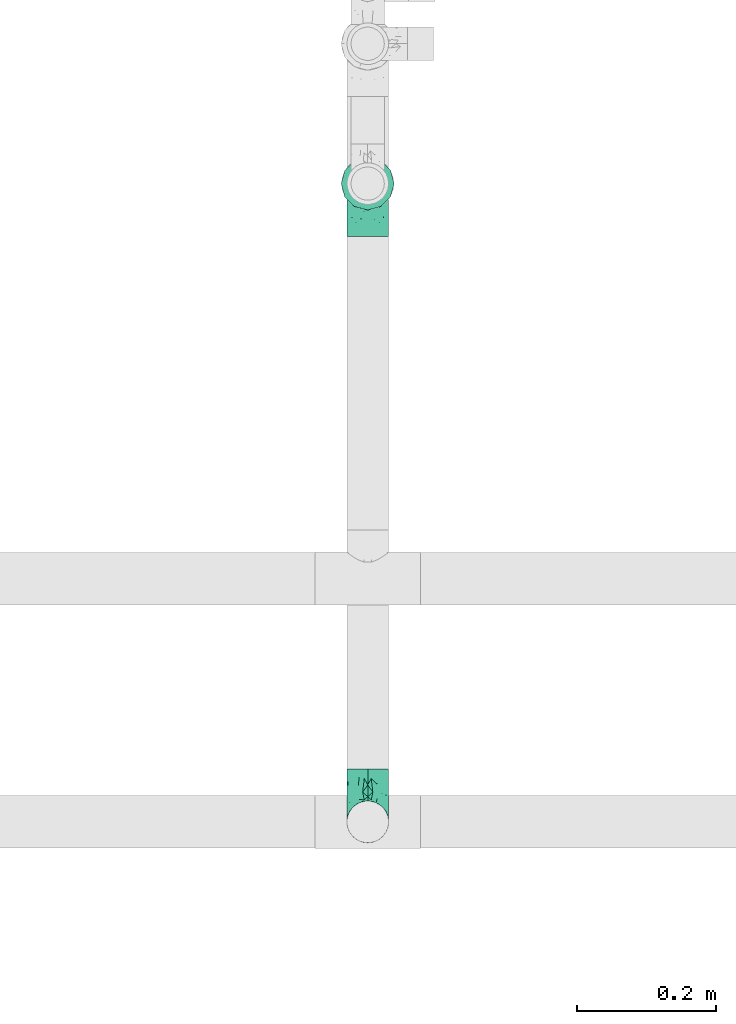
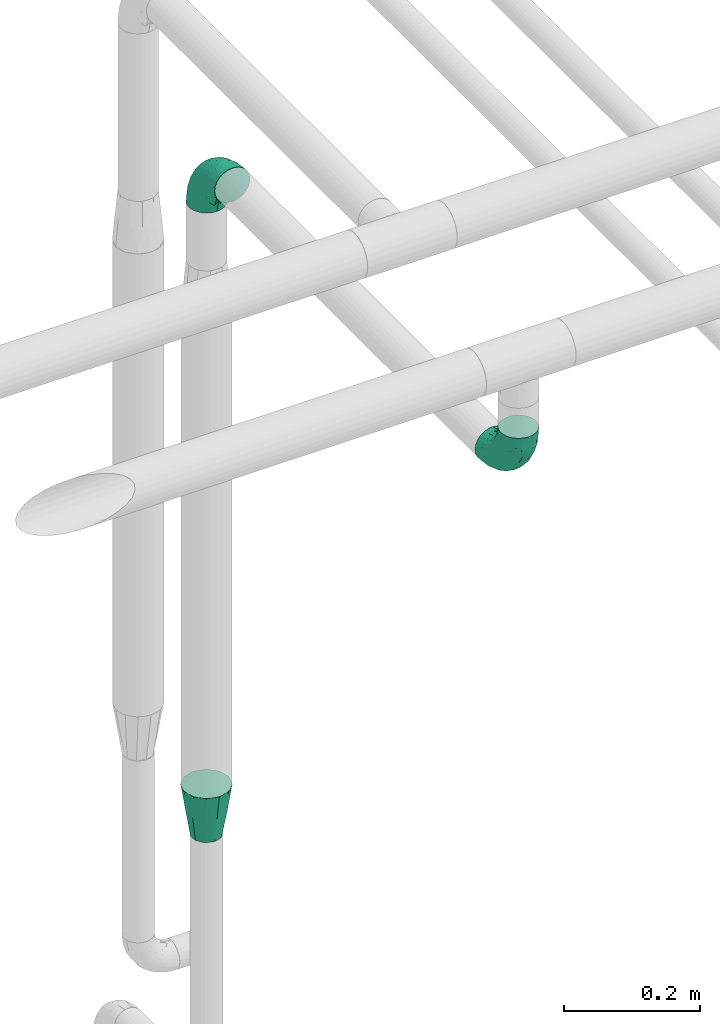
# One storey, part 786 of 827: 3 flow fittings.
"""IFC2X3 building model written with IfcOpenShell, lengths in millimetres."""

from ifc_helpers import new_model, entity, si_unit, converted_unit, derived_unit, direction, frame, origin, place, context, subcontext, project, spatial, faceted_brep, source, transform, mapped, material, type_object, type_shapes, element, save


model = new_model("IFC2X3")

# Units and contexts
model_context = context("Model", 3, precision=0.01, world=origin(), true_north=direction((6.12303176911189e-17, 1.0)))
body_context = subcontext(model_context, "Body", "Model", "MODEL_VIEW")
ifc_project = project(units=[si_unit("LENGTHUNIT", "METRE", prefix="MILLI"), si_unit("AREAUNIT", "SQUARE_METRE"), si_unit("VOLUMEUNIT", "CUBIC_METRE"), converted_unit("PLANEANGLEUNIT", "DEGREE", entity("IfcRatioMeasure", 0.0174532925199433), si_unit("PLANEANGLEUNIT", "RADIAN"), dimensions=[0, 0, 0, 0, 0, 0, 0]), si_unit("MASSUNIT", "GRAM", prefix="KILO"), derived_unit("MASSDENSITYUNIT", [(si_unit("MASSUNIT", "GRAM", prefix="KILO"), 1), (si_unit("LENGTHUNIT", "METRE"), -3)]), derived_unit("MOMENTOFINERTIAUNIT", [(si_unit("LENGTHUNIT", "METRE"), 4)]), si_unit("TIMEUNIT", "SECOND"), si_unit("FREQUENCYUNIT", "HERTZ"), si_unit("THERMODYNAMICTEMPERATUREUNIT", "DEGREE_CELSIUS"), derived_unit("THERMALTRANSMITTANCEUNIT", [(si_unit("MASSUNIT", "GRAM", prefix="KILO"), 1), (si_unit("THERMODYNAMICTEMPERATUREUNIT", "KELVIN"), -1), (si_unit("TIMEUNIT", "SECOND"), -3)]), derived_unit("VOLUMETRICFLOWRATEUNIT", [(si_unit("LENGTHUNIT", "METRE"), 3), (si_unit("TIMEUNIT", "SECOND"), -1)]), derived_unit("MASSFLOWRATEUNIT", [(si_unit("MASSUNIT", "GRAM", prefix="KILO"), 1), (si_unit("TIMEUNIT", "SECOND"), -1)]), derived_unit("ROTATIONALFREQUENCYUNIT", [(si_unit("TIMEUNIT", "SECOND"), -1)]), si_unit("ELECTRICCURRENTUNIT", "AMPERE"), si_unit("ELECTRICVOLTAGEUNIT", "VOLT"), si_unit("POWERUNIT", "WATT"), si_unit("FORCEUNIT", "NEWTON", prefix="KILO"), si_unit("ILLUMINANCEUNIT", "LUX"), si_unit("LUMINOUSFLUXUNIT", "LUMEN"), si_unit("LUMINOUSINTENSITYUNIT", "CANDELA"), derived_unit("USERDEFINED", [(si_unit("MASSUNIT", "GRAM", prefix="KILO"), -1), (si_unit("LENGTHUNIT", "METRE"), -2), (si_unit("TIMEUNIT", "SECOND"), 3), (si_unit("LUMINOUSFLUXUNIT", "LUMEN"), 1)]), derived_unit("LINEARVELOCITYUNIT", [(si_unit("LENGTHUNIT", "METRE"), 1), (si_unit("TIMEUNIT", "SECOND"), -1)]), si_unit("PRESSUREUNIT", "PASCAL"), derived_unit("USERDEFINED", [(si_unit("LENGTHUNIT", "METRE"), -2), (si_unit("MASSUNIT", "GRAM", prefix="KILO"), 1), (si_unit("TIMEUNIT", "SECOND"), -2)]), derived_unit("LINEARFORCEUNIT", [(si_unit("MASSUNIT", "GRAM", prefix="KILO"), 1), (si_unit("LENGTHUNIT", "METRE"), 1), (si_unit("TIMEUNIT", "SECOND"), -2), (si_unit("LENGTHUNIT", "METRE"), -1)]), derived_unit("PLANARFORCEUNIT", [(si_unit("MASSUNIT", "GRAM", prefix="KILO"), 1), (si_unit("LENGTHUNIT", "METRE"), 1), (si_unit("TIMEUNIT", "SECOND"), -2), (si_unit("LENGTHUNIT", "METRE"), -2)])], contexts=[model_context])

# Site, building, storey
site_placement = place(None, origin())
site = spatial("IfcSite", under=ifc_project, at=site_placement, CompositionType="ELEMENT")
building_placement = place(site_placement, origin())
building = spatial("IfcBuilding", under=site, at=building_placement, CompositionType="ELEMENT")
storey_placement = place(building_placement, frame((0.0, 0.0, 28200.0)))
storey = spatial("IfcBuildingStorey", under=building, at=storey_placement, Name="08", CompositionType="ELEMENT", Elevation=28200.0)

# Flow fittings
ifc_material = material()
pipe_fitting_type_1 = type_object("IfcPipeFittingType", Name="ADSK_1", PredefinedType="NOTDEFINED", material=ifc_material)
shared_shape_1 = source(origin(), body_context, "Body", "Brep", [
    faceted_brep([(-76.0, 15.07, -26.11), (-76.0, 7.8, -29.12), (-76.0, 0.0, -30.15), (-76.0, -7.8, -29.12), (-76.0, -15.08, -26.11), (-76.0, -21.32, -21.32), (-76.0, -26.11, -15.08), (-76.0, -29.12, -7.8), (-76.0, -30.15, 0.0), (-76.0, -29.12, 7.8), (-76.0, -26.11, 15.07), (-76.0, -21.32, 21.32), (-76.0, -15.08, 26.11), (-76.0, -7.8, 29.12), (-76.0, 0.0, 30.15), (-76.0, 7.8, 29.12), (-76.0, 15.07, 26.11), (-76.0, 21.32, 21.32), (-76.0, 26.11, 15.07), (-76.0, 29.12, 7.8), (-76.0, 30.15, 0.0), (-76.0, 29.12, -7.8), (-76.0, 26.11, -15.08), (-76.0, 21.32, -21.32), (0.0, 76.0, -30.15), (-7.8, 76.0, -29.12), (-15.07, 76.0, -26.11), (-21.32, 76.0, -21.32), (-26.11, 76.0, -15.08), (-29.12, 76.0, -7.8), (-30.15, 76.0, 0.0), (-29.12, 76.0, 7.8), (-26.11, 76.0, 15.07), (-21.32, 76.0, 21.32), (-15.07, 76.0, 26.11), (-7.8, 76.0, 29.12), (0.0, 76.0, 30.15), (7.8, 76.0, 29.12), (15.08, 76.0, 26.11), (21.32, 76.0, 21.32), (26.11, 76.0, 15.07), (29.12, 76.0, 7.8), (30.15, 76.0, 0.0), (29.12, 76.0, -7.8), (26.11, 76.0, -15.08), (21.32, 76.0, -21.32), (15.08, 76.0, -26.11), (7.8, 76.0, -29.12), (10.79, 31.43, 21.07), (4.32, 31.7, 25.72), (1.65, 15.19, 19.92), (-61.17, -27.8, 0.0), (-51.1, -25.49, 9.84), (-56.14, -10.61, 27.27), (-31.7, -4.32, 25.72), (-39.75, 1.72, 29.41), (-43.2, -24.95, 0.0), (-1.86, 1.86, 0.0), (4.49, 7.65, 5.78), (-7.82, -4.61, 5.83), (-56.21, -22.79, 17.21), (-58.98, -3.38, 29.7), (-53.96, 5.6, 30.07), (-10.86, 10.86, 25.48), (-17.2, -2.6, 20.44), (-49.15, -16.01, 22.7), (-22.18, -14.24, 7.99), (-28.4, -17.42, 0.0), (-13.61, -9.88, 0.0), (-39.0, 23.48, 27.76), (-58.76, 12.54, 28.36), (-41.61, 15.41, 29.48), (16.01, 49.15, 22.7), (-58.55, 25.93, 19.53), (-51.53, 33.5, 13.51), (-64.92, 28.76, 12.4), (-7.48, 23.14, 28.25), (-1.72, 39.75, 29.41), (-12.04, 27.88, 29.88), (-63.91, 18.81, 24.52), (-11.63, 65.16, 28.18), (-4.97, 57.02, 30.05), (9.88, 13.61, 0.0), (-62.5, 31.74, 5.02), (-45.17, 30.98, 21.2), (-21.78, 9.76, 28.58), (10.61, 56.14, 27.27), (-32.09, 54.42, 13.26), (22.79, 56.21, 17.21), (15.38, 31.17, 15.63), (25.49, 51.1, 9.84), (21.84, 36.35, 5.92), (24.95, 43.2, 0.0), (3.38, 58.98, 29.7), (-31.17, -15.38, 15.63), (-39.39, 41.78, 15.45), (-34.56, 41.13, 20.79), (-39.81, -23.25, 5.49), (27.8, 61.17, 0.0), (-31.74, 62.5, 5.02), (-53.07, 36.29, 0.0), (-42.95, 42.95, 7.29), (-36.29, 53.07, 0.0), (-19.83, 58.51, 24.79), (-25.48, 60.2, 19.41), (-14.53, 50.96, 28.57), (-13.31, 37.09, 30.07), (-26.16, 40.06, 26.4), (-32.43, -10.35, 21.9), (17.42, 28.4, 0.0), (14.24, 22.18, 7.99), (-38.67, 9.72, 30.15), (-24.66, 17.36, 30.09), (-37.08, 31.49, 24.99), (-49.27, 22.83, 25.24), (-20.8, 38.81, 28.63), (-27.58, 27.58, 29.2), (-36.07, -20.23, 10.71), (-15.19, -6.16, 14.9), (6.6, 15.4, 14.49), (-2.51, 2.51, 11.35), (-65.16, 11.63, -28.18), (-49.15, -16.01, -22.7), (-57.02, 4.97, -30.05), (-25.93, 58.55, -19.53), (-33.5, 51.53, -13.51), (-28.76, 64.92, -12.4), (-60.2, 25.48, -19.41), (-58.51, 19.83, -24.79), (-7.65, -4.49, -5.78), (-62.5, 31.74, -5.02), (-50.96, 14.53, -28.57), (-37.09, 13.31, -30.07), (-42.95, 42.95, -7.29), (25.49, 51.1, -9.84), (22.79, 56.21, -17.21), (-40.06, 26.16, -26.4), (3.38, 58.98, -29.7), (-5.6, 53.96, -30.07), (-27.88, 12.04, -29.88), (-9.76, 21.78, -28.58), (-23.14, 7.48, -28.25), (-51.1, -25.49, -9.84), (15.38, 31.17, -15.63), (16.01, 49.15, -22.7), (-23.48, 39.0, -27.76), (-12.54, 58.76, -28.36), (-15.41, 41.61, -29.48), (-56.21, -22.79, -17.21), (-9.72, 38.67, -30.15), (-17.36, 24.66, -30.09), (-22.18, -14.24, -7.99), (-41.13, 34.56, -20.79), (-31.74, 62.5, -5.02), (-58.98, -3.38, -29.7), (-31.17, -15.38, -15.63), (-56.14, -10.61, -27.27), (14.24, 22.18, -7.99), (23.25, 39.81, -5.49), (-31.49, 37.08, -24.99), (4.61, 7.82, -5.83), (-15.19, -6.16, -14.9), (1.65, 15.19, -19.92), (-2.51, 2.51, -11.35), (-18.81, 63.91, -24.52), (-32.59, -11.62, -20.84), (-31.7, -4.32, -25.72), (-17.2, -2.6, -20.44), (-39.75, 1.72, -29.41), (-54.42, 32.09, -13.26), (-30.98, 45.17, -21.2), (10.61, 56.14, -27.27), (10.23, 31.31, -21.52), (4.32, 31.7, -25.72), (-41.78, 39.39, -15.45), (-1.72, 39.75, -29.41), (-36.35, -21.84, -5.92), (-22.83, 49.27, -25.24), (-38.81, 20.8, -28.63), (-27.58, 27.58, -29.2), (-10.86, 10.86, -25.48), (20.23, 36.07, -10.71), (6.6, 15.4, -14.49)], [[[0, 1, 2, 3, 4, 5, 6, 7, 8, 9, 10, 11, 12, 13, 14, 15, 16, 17, 18, 19, 20, 21, 22, 23]], [[24, 25, 26, 27, 28, 29, 30, 31, 32, 33, 34, 35, 36, 37, 38, 39, 40, 41, 42, 43, 44, 45, 46, 47]], [[48, 49, 50]], [[51, 52, 9]], [[53, 54, 55]], [[9, 52, 10]], [[56, 52, 51]], [[57, 58, 59]], [[11, 10, 60]], [[14, 61, 62]], [[63, 54, 64]], [[65, 12, 11]], [[65, 53, 12]], [[66, 67, 68]], [[69, 70, 71]], [[72, 39, 38]], [[73, 74, 75]], [[15, 70, 16]], [[76, 77, 78]], [[16, 79, 17]], [[13, 61, 14]], [[35, 80, 81]], [[14, 62, 15]], [[17, 73, 18]], [[58, 57, 82]], [[20, 19, 83]], [[75, 19, 18]], [[70, 15, 62]], [[73, 84, 74]], [[78, 85, 76]], [[38, 86, 72]], [[32, 31, 87]], [[88, 89, 90]], [[91, 92, 90]], [[72, 86, 49]], [[36, 93, 37]], [[75, 83, 19]], [[36, 35, 81]], [[60, 94, 65]], [[40, 90, 41]], [[95, 96, 87]], [[88, 90, 40]], [[66, 97, 67]], [[90, 98, 41]], [[40, 39, 88]], [[99, 31, 30]], [[20, 83, 100]], [[101, 102, 100]], [[52, 60, 10]], [[102, 99, 30]], [[96, 103, 104]], [[83, 101, 100]], [[12, 53, 13]], [[104, 103, 33]], [[105, 106, 81]], [[107, 105, 103]], [[64, 54, 108]], [[80, 103, 105]], [[80, 35, 34]], [[34, 33, 103]], [[86, 38, 37]], [[109, 110, 82]], [[71, 111, 112]], [[69, 107, 113]], [[79, 73, 17]], [[114, 113, 84]], [[33, 32, 104]], [[115, 107, 116]], [[105, 115, 106]], [[93, 81, 77]], [[54, 53, 65]], [[61, 53, 55]], [[108, 94, 64]], [[54, 63, 85]], [[93, 86, 37]], [[77, 76, 49]], [[77, 49, 86]], [[49, 63, 50]], [[60, 52, 117]], [[65, 11, 60]], [[39, 72, 88]], [[89, 88, 72]], [[71, 70, 62]], [[79, 70, 114]], [[103, 96, 107]], [[69, 113, 114]], [[112, 106, 116]], [[77, 81, 106]], [[112, 116, 71]], [[112, 55, 85]], [[64, 50, 63]], [[57, 59, 68]], [[32, 87, 104]], [[96, 104, 87]], [[94, 118, 64]], [[50, 119, 89]], [[50, 64, 118]], [[50, 89, 48]], [[81, 93, 36]], [[86, 93, 77]], [[53, 61, 13]], [[62, 61, 55]], [[71, 62, 111]], [[69, 71, 116]], [[95, 101, 74]], [[99, 101, 87]], [[118, 66, 59]], [[117, 97, 66]], [[117, 66, 94]], [[91, 89, 110]], [[91, 110, 109]], [[110, 89, 119]], [[9, 8, 51]], [[98, 90, 92]], [[98, 42, 41]], [[101, 83, 74]], [[101, 99, 102]], [[87, 31, 99]], [[62, 55, 111]], [[55, 112, 111]], [[107, 69, 116]], [[70, 69, 114]], [[107, 96, 113]], [[84, 113, 96]], [[84, 96, 95]], [[114, 84, 73]], [[70, 79, 16]], [[73, 79, 114]], [[54, 85, 55]], [[76, 85, 63]], [[49, 76, 63]], [[77, 106, 78]], [[106, 112, 78]], [[85, 78, 112]], [[73, 75, 18]], [[83, 75, 74]], [[103, 80, 34]], [[81, 80, 105]], [[101, 95, 87]], [[84, 95, 74]], [[106, 115, 116]], [[105, 107, 115]], [[110, 119, 58]], [[110, 58, 82]], [[58, 120, 59]], [[118, 59, 120]], [[66, 68, 59]], [[54, 65, 108]], [[94, 108, 65]], [[66, 118, 94]], [[50, 118, 120]], [[50, 120, 119]], [[119, 120, 58]], [[89, 72, 48]], [[49, 48, 72]], [[60, 117, 94]], [[117, 52, 97]], [[52, 56, 97]], [[67, 97, 56]], [[92, 91, 109]], [[89, 91, 90]], [[121, 1, 0]], [[122, 5, 4]], [[2, 1, 123]], [[124, 125, 126]], [[127, 128, 23]], [[68, 129, 57]], [[100, 130, 20]], [[131, 132, 123]], [[133, 100, 102]], [[134, 135, 44]], [[131, 128, 136]], [[24, 137, 138]], [[139, 140, 141]], [[121, 128, 131]], [[6, 142, 7]], [[135, 143, 144]], [[142, 51, 7]], [[145, 146, 147]], [[142, 6, 148]], [[147, 149, 150]], [[151, 68, 67]], [[152, 128, 127]], [[30, 153, 102]], [[43, 42, 98]], [[154, 3, 2]], [[155, 142, 148]], [[156, 4, 3]], [[24, 138, 25]], [[153, 133, 102]], [[157, 158, 109]], [[30, 29, 153]], [[145, 136, 159]], [[27, 124, 28]], [[57, 160, 82]], [[161, 162, 163]], [[27, 26, 164]], [[146, 26, 25]], [[165, 166, 167]], [[24, 47, 137]], [[141, 168, 139]], [[22, 21, 169]], [[125, 124, 170]], [[146, 25, 138]], [[46, 144, 171]], [[156, 122, 4]], [[0, 23, 128]], [[1, 121, 123]], [[109, 82, 157]], [[45, 44, 135]], [[144, 46, 45]], [[134, 43, 98]], [[130, 21, 20]], [[134, 98, 92]], [[172, 173, 144]], [[46, 171, 47]], [[43, 134, 44]], [[174, 152, 169]], [[171, 173, 175]], [[6, 5, 148]], [[126, 29, 28]], [[176, 56, 142]], [[122, 156, 166]], [[164, 124, 27]], [[177, 159, 170]], [[23, 22, 127]], [[178, 136, 179]], [[131, 178, 132]], [[154, 123, 168]], [[154, 156, 3]], [[168, 141, 166]], [[168, 166, 156]], [[166, 180, 167]], [[173, 171, 144]], [[137, 171, 175]], [[172, 143, 162]], [[173, 180, 140]], [[5, 122, 148]], [[155, 148, 122]], [[135, 134, 181]], [[144, 45, 135]], [[147, 146, 138]], [[164, 146, 177]], [[128, 152, 136]], [[145, 159, 177]], [[150, 132, 179]], [[168, 123, 132]], [[150, 179, 147]], [[150, 175, 140]], [[57, 129, 160]], [[155, 165, 167]], [[22, 169, 127]], [[152, 127, 169]], [[162, 167, 180]], [[161, 155, 167]], [[173, 162, 180]], [[182, 162, 143]], [[123, 154, 2]], [[156, 154, 168]], [[171, 137, 47]], [[138, 137, 175]], [[147, 138, 149]], [[145, 147, 179]], [[174, 133, 125]], [[130, 133, 169]], [[176, 155, 151]], [[176, 151, 67]], [[151, 155, 161]], [[182, 157, 160]], [[181, 158, 157]], [[181, 157, 143]], [[51, 142, 56]], [[51, 8, 7]], [[133, 130, 100]], [[169, 21, 130]], [[126, 153, 29]], [[133, 153, 125]], [[138, 175, 149]], [[175, 150, 149]], [[136, 145, 179]], [[146, 145, 177]], [[136, 152, 159]], [[170, 159, 152]], [[170, 152, 174]], [[177, 170, 124]], [[146, 164, 26]], [[124, 164, 177]], [[173, 140, 175]], [[141, 140, 180]], [[166, 141, 180]], [[168, 132, 139]], [[132, 150, 139]], [[140, 139, 150]], [[124, 126, 28]], [[153, 126, 125]], [[128, 121, 0]], [[123, 121, 131]], [[133, 174, 169]], [[170, 174, 125]], [[132, 178, 179]], [[131, 136, 178]], [[151, 161, 129]], [[151, 129, 68]], [[129, 163, 160]], [[182, 160, 163]], [[157, 82, 160]], [[155, 122, 165]], [[166, 165, 122]], [[162, 161, 167]], [[161, 163, 129]], [[143, 172, 144]], [[162, 173, 172]], [[157, 182, 143]], [[163, 162, 182]], [[56, 176, 67]], [[155, 176, 142]], [[135, 181, 143]], [[181, 134, 158]], [[134, 92, 158]], [[109, 158, 92]]]),
])
type_shapes(pipe_fitting_type_1, [shared_shape_1])
flow_fitting_1_placement = place(storey_placement, frame((15025.95, 15318.04, 2600.0), z_axis=(-1.0, 0.0, 0.0), x_axis=(0.0, 1.0, -5.95708716508338e-07)))
element("IfcFlowFitting", 1, at=flow_fitting_1_placement, inside=storey, type_object=pipe_fitting_type_1, material=ifc_material, Name="ADSK_1", ObjectType="ADSK_1", context=body_context, shape_type="MappedRepresentation", body=[
    mapped(shared_shape_1, transform((0.0, 0.0, 0.0), scale=1.0)),
])
pipe_fitting_type_2 = type_object("IfcPipeFittingType", Name="ADSK_1", PredefinedType="NOTDEFINED", material=ifc_material)
shared_shape_2 = source(origin(), body_context, "Body", "Brep", [
    faceted_brep([(89.0, 19.02, -32.97), (89.0, 25.99, -26.0), (89.0, 32.95, -19.04), (89.0, 35.5, -9.53), (89.0, 38.05, -0.02), (89.0, 35.5, 9.5), (89.0, 32.95, 19.01), (89.0, 25.99, 25.97), (89.0, 19.02, 32.94), (89.0, 9.51, 35.49), (89.0, 0.0, 38.03), (89.0, -9.51, 35.49), (89.0, -19.03, 32.94), (89.0, -25.99, 25.97), (89.0, -32.95, 19.01), (89.0, -35.5, 9.5), (89.0, -38.05, -0.02), (89.0, -35.5, -9.53), (89.0, -32.95, -19.04), (89.0, -25.99, -26.0), (89.0, -19.03, -32.97), (89.0, -9.51, -35.52), (89.0, 0.0, -38.07), (89.0, 9.51, -35.52), (0.0, 19.54, 14.2), (0.0, 21.84, 7.1), (0.0, 24.15, 0.0), (0.0, 21.84, -7.1), (0.0, 19.54, -14.2), (0.0, 13.5, -18.58), (0.0, 7.46, -22.97), (0.0, 0.0, -22.97), (0.0, -7.46, -22.97), (0.0, -13.5, -18.58), (0.0, -19.54, -14.2), (0.0, -21.84, -7.1), (0.0, -24.15, 0.0), (0.0, -21.84, 7.1), (0.0, -19.54, 14.2), (0.0, -13.5, 18.58), (0.0, -7.46, 22.97), (0.0, 0.0, 22.97), (0.0, 7.46, 22.97), (0.0, 13.5, 18.58), (42.75, -30.0, -7.08), (42.46, -27.91, -12.99), (48.81, -9.76, -30.25), (39.14, -14.23, -26.72), (49.37, -25.28, -19.4), (44.38, -20.22, -23.61), (44.38, 23.61, -20.22), (39.14, 26.71, -14.23), (44.5, -4.06, -30.84), (45.84, 10.19, -29.61), (49.37, 19.4, -25.28), (44.72, 29.79, -9.06), (44.5, 4.06, -30.84), (44.5, -31.1, -0.01), (42.65, -30.81, -0.01), (42.66, 30.81, -0.01), (44.5, 31.1, -0.01), (42.75, 30.0, 7.07), (42.46, 27.91, 12.97), (48.81, 9.76, 30.23), (39.14, 14.23, 26.7), (49.37, 25.28, 19.39), (44.38, 20.22, 23.6), (44.38, -23.61, 20.21), (39.14, -26.71, 14.22), (44.5, 4.06, 30.83), (45.84, -10.19, 29.6), (49.37, -19.4, 25.27), (44.72, -29.79, 9.05), (44.5, -4.06, 30.83)], [[[0, 1, 2, 3, 4, 5, 6, 7, 8, 9, 10, 11, 12, 13, 14, 15, 16, 17, 18, 19, 20, 21, 22, 23]], [[24, 25, 26, 27, 28, 29, 30, 31, 32, 33, 34, 35, 36, 37, 38, 39, 40, 41, 42, 43]], [[44, 45, 17]], [[20, 46, 21]], [[33, 32, 47]], [[19, 48, 49]], [[34, 49, 48]], [[50, 51, 2]], [[45, 48, 18]], [[49, 20, 19]], [[21, 52, 22]], [[48, 45, 34]], [[53, 29, 54]], [[35, 45, 44]], [[45, 18, 17]], [[55, 51, 27]], [[18, 48, 19]], [[22, 56, 23]], [[44, 16, 57, 58, 36]], [[53, 54, 0]], [[59, 55, 26]], [[49, 34, 33]], [[34, 45, 35]], [[31, 30, 56, 52, 32]], [[49, 33, 47]], [[47, 20, 49]], [[32, 52, 46]], [[20, 47, 46]], [[53, 23, 56]], [[56, 22, 52]], [[36, 35, 44]], [[52, 21, 46]], [[53, 56, 30]], [[1, 54, 50]], [[0, 23, 53]], [[53, 30, 29]], [[2, 1, 50]], [[0, 54, 1]], [[50, 29, 28]], [[29, 50, 54]], [[50, 28, 51]], [[28, 27, 51]], [[59, 3, 55]], [[55, 27, 26]], [[2, 51, 55]], [[3, 59, 60, 4]], [[2, 55, 3]], [[16, 44, 17]], [[32, 46, 47]], [[61, 62, 5]], [[8, 63, 9]], [[43, 42, 64]], [[7, 65, 66]], [[24, 66, 65]], [[67, 68, 14]], [[62, 65, 6]], [[66, 8, 7]], [[9, 69, 10]], [[65, 62, 24]], [[70, 39, 71]], [[25, 62, 61]], [[62, 6, 5]], [[72, 68, 37]], [[6, 65, 7]], [[10, 73, 11]], [[61, 4, 60, 59, 26]], [[70, 71, 12]], [[58, 72, 36]], [[66, 24, 43]], [[24, 62, 25]], [[41, 40, 73, 69, 42]], [[66, 43, 64]], [[64, 8, 66]], [[42, 69, 63]], [[8, 64, 63]], [[70, 11, 73]], [[73, 10, 69]], [[26, 25, 61]], [[69, 9, 63]], [[70, 73, 40]], [[13, 71, 67]], [[12, 11, 70]], [[70, 40, 39]], [[14, 13, 67]], [[12, 71, 13]], [[67, 39, 38]], [[39, 67, 71]], [[67, 38, 68]], [[38, 37, 68]], [[58, 15, 72]], [[72, 37, 36]], [[14, 68, 72]], [[15, 58, 57, 16]], [[14, 72, 15]], [[4, 61, 5]], [[42, 63, 64]]]),
])
type_shapes(pipe_fitting_type_2, [shared_shape_2])
flow_fitting_2_placement = place(storey_placement, frame((15025.81, 15318.04, 1388.64), z_axis=(1.0, 0.0, 0.0), x_axis=(0.0, 0.0, 1.0)))
element("IfcFlowFitting", 2, at=flow_fitting_2_placement, inside=storey, type_object=pipe_fitting_type_2, material=ifc_material, Name="ADSK_1", ObjectType="ADSK_1", context=body_context, shape_type="MappedRepresentation", body=[
    mapped(shared_shape_2, transform((0.0, 0.0, 0.0), scale=1.0)),
])
pipe_fitting_type_3 = type_object("IfcPipeFittingType", Name="ADSK_1", PredefinedType="NOTDEFINED", material=ifc_material)
shared_shape_3 = source(origin(), body_context, "Body", "Brep", [
    faceted_brep([(-76.0, 15.07, -26.11), (-76.0, 7.8, -29.12), (-76.0, 0.0, -30.15), (-76.0, -7.8, -29.12), (-76.0, -15.08, -26.11), (-76.0, -21.32, -21.32), (-76.0, -26.11, -15.08), (-76.0, -29.12, -7.8), (-76.0, -30.15, 0.0), (-76.0, -29.12, 7.8), (-76.0, -26.11, 15.07), (-76.0, -21.32, 21.32), (-76.0, -15.08, 26.11), (-76.0, -7.8, 29.12), (-76.0, 0.0, 30.15), (-76.0, 7.8, 29.12), (-76.0, 15.07, 26.11), (-76.0, 21.32, 21.32), (-76.0, 26.11, 15.07), (-76.0, 29.12, 7.8), (-76.0, 30.15, 0.0), (-76.0, 29.12, -7.8), (-76.0, 26.11, -15.08), (-76.0, 21.32, -21.32), (0.0, 76.0, -30.15), (-7.8, 76.0, -29.12), (-15.08, 76.0, -26.11), (-21.32, 76.0, -21.32), (-26.11, 76.0, -15.08), (-29.12, 76.0, -7.8), (-30.15, 76.0, 0.0), (-29.12, 76.0, 7.8), (-26.11, 76.0, 15.07), (-21.32, 76.0, 21.32), (-15.08, 76.0, 26.11), (-7.8, 76.0, 29.12), (0.0, 76.0, 30.15), (7.8, 76.0, 29.12), (15.07, 76.0, 26.11), (21.32, 76.0, 21.32), (26.11, 76.0, 15.07), (29.12, 76.0, 7.8), (30.15, 76.0, 0.0), (29.12, 76.0, -7.8), (26.11, 76.0, -15.08), (21.32, 76.0, -21.32), (15.07, 76.0, -26.11), (7.8, 76.0, -29.12), (10.79, 31.43, 21.07), (4.32, 31.7, 25.72), (1.65, 15.19, 19.92), (-61.17, -27.8, 0.0), (-51.1, -25.49, 9.84), (-56.14, -10.61, 27.27), (-31.7, -4.32, 25.72), (-39.75, 1.72, 29.41), (-43.2, -24.95, 0.0), (-1.86, 1.86, 0.0), (4.49, 7.65, 5.78), (-7.82, -4.61, 5.83), (-56.21, -22.79, 17.21), (-58.98, -3.38, 29.7), (-53.96, 5.6, 30.07), (-10.86, 10.86, 25.48), (-17.2, -2.6, 20.44), (-49.15, -16.01, 22.7), (-22.18, -14.24, 7.99), (-28.4, -17.42, 0.0), (-13.61, -9.88, 0.0), (-39.0, 23.48, 27.76), (-58.76, 12.54, 28.36), (-41.61, 15.41, 29.48), (16.01, 49.15, 22.7), (-58.55, 25.93, 19.53), (-51.53, 33.5, 13.51), (-64.92, 28.76, 12.4), (-7.48, 23.14, 28.25), (-1.72, 39.75, 29.41), (-12.04, 27.88, 29.88), (-63.91, 18.81, 24.52), (-11.63, 65.16, 28.18), (-4.97, 57.02, 30.05), (9.88, 13.61, 0.0), (-62.5, 31.74, 5.02), (-45.17, 30.98, 21.2), (-21.78, 9.76, 28.58), (10.61, 56.14, 27.27), (-32.09, 54.42, 13.26), (22.79, 56.21, 17.21), (15.38, 31.17, 15.63), (25.49, 51.1, 9.84), (21.84, 36.35, 5.92), (24.95, 43.2, 0.0), (3.38, 58.98, 29.7), (-31.17, -15.38, 15.63), (-39.39, 41.78, 15.45), (-34.56, 41.13, 20.79), (-39.81, -23.25, 5.49), (27.8, 61.17, 0.0), (-31.74, 62.5, 5.02), (-53.08, 36.29, 0.0), (-42.95, 42.95, 7.29), (-36.29, 53.08, 0.0), (-19.83, 58.51, 24.79), (-25.48, 60.2, 19.41), (-14.53, 50.96, 28.57), (-13.31, 37.09, 30.07), (-26.16, 40.06, 26.4), (-32.43, -10.35, 21.9), (17.42, 28.4, 0.0), (14.24, 22.18, 7.99), (-38.67, 9.72, 30.15), (-24.66, 17.36, 30.09), (-37.08, 31.49, 24.99), (-49.27, 22.83, 25.24), (-20.8, 38.81, 28.63), (-27.58, 27.58, 29.2), (-36.07, -20.23, 10.71), (-15.19, -6.16, 14.9), (6.6, 15.4, 14.49), (-2.51, 2.51, 11.35), (-65.16, 11.63, -28.18), (-49.15, -16.01, -22.7), (-57.02, 4.97, -30.05), (-25.93, 58.55, -19.53), (-33.5, 51.53, -13.51), (-28.76, 64.92, -12.4), (-60.2, 25.48, -19.41), (-58.51, 19.83, -24.79), (-7.65, -4.49, -5.78), (-62.5, 31.74, -5.02), (-50.96, 14.53, -28.57), (-37.09, 13.31, -30.07), (-42.95, 42.95, -7.29), (25.49, 51.1, -9.84), (22.79, 56.21, -17.21), (-40.06, 26.16, -26.4), (3.38, 58.98, -29.7), (-5.6, 53.96, -30.07), (-27.88, 12.04, -29.88), (-9.76, 21.78, -28.58), (-23.14, 7.48, -28.25), (-51.1, -25.49, -9.84), (15.38, 31.17, -15.63), (16.01, 49.15, -22.7), (-23.48, 39.0, -27.76), (-12.54, 58.76, -28.36), (-15.41, 41.61, -29.48), (-56.21, -22.79, -17.21), (-9.72, 38.67, -30.15), (-17.36, 24.66, -30.09), (-22.18, -14.24, -7.99), (-41.13, 34.56, -20.79), (-31.74, 62.5, -5.02), (-58.98, -3.38, -29.7), (-31.17, -15.38, -15.63), (-56.14, -10.61, -27.27), (14.24, 22.18, -7.99), (23.25, 39.81, -5.49), (-31.49, 37.08, -24.99), (4.61, 7.82, -5.83), (-15.19, -6.16, -14.9), (1.65, 15.19, -19.92), (-2.51, 2.51, -11.35), (-18.81, 63.91, -24.52), (-32.59, -11.62, -20.84), (-31.7, -4.32, -25.72), (-17.2, -2.6, -20.44), (-39.75, 1.72, -29.41), (-54.42, 32.09, -13.26), (-30.98, 45.17, -21.2), (10.61, 56.14, -27.27), (10.23, 31.31, -21.52), (4.32, 31.7, -25.72), (-41.78, 39.39, -15.45), (-1.72, 39.75, -29.41), (-36.35, -21.84, -5.92), (-22.83, 49.27, -25.24), (-38.81, 20.8, -28.63), (-10.86, 10.86, -25.48), (20.23, 36.07, -10.71), (-27.58, 27.58, -29.2), (6.6, 15.4, -14.49)], [[[0, 1, 2, 3, 4, 5, 6, 7, 8, 9, 10, 11, 12, 13, 14, 15, 16, 17, 18, 19, 20, 21, 22, 23]], [[24, 25, 26, 27, 28, 29, 30, 31, 32, 33, 34, 35, 36, 37, 38, 39, 40, 41, 42, 43, 44, 45, 46, 47]], [[48, 49, 50]], [[51, 52, 9]], [[53, 54, 55]], [[9, 52, 10]], [[56, 52, 51]], [[57, 58, 59]], [[11, 10, 60]], [[14, 61, 62]], [[63, 54, 64]], [[65, 12, 11]], [[65, 53, 12]], [[66, 67, 68]], [[69, 70, 71]], [[72, 39, 38]], [[73, 74, 75]], [[15, 70, 16]], [[76, 77, 78]], [[16, 79, 17]], [[13, 61, 14]], [[35, 80, 81]], [[14, 62, 15]], [[17, 73, 18]], [[57, 82, 58]], [[20, 19, 83]], [[75, 19, 18]], [[70, 15, 62]], [[73, 84, 74]], [[78, 85, 76]], [[38, 86, 72]], [[32, 31, 87]], [[88, 89, 90]], [[91, 92, 90]], [[72, 86, 49]], [[36, 93, 37]], [[75, 83, 19]], [[36, 35, 81]], [[60, 94, 65]], [[40, 90, 41]], [[95, 96, 87]], [[88, 90, 40]], [[66, 97, 67]], [[90, 98, 41]], [[40, 39, 88]], [[99, 31, 30]], [[20, 83, 100]], [[101, 102, 100]], [[52, 60, 10]], [[102, 99, 30]], [[96, 103, 104]], [[83, 101, 100]], [[12, 53, 13]], [[104, 103, 33]], [[105, 106, 81]], [[107, 105, 103]], [[64, 54, 108]], [[80, 103, 105]], [[80, 35, 34]], [[34, 33, 103]], [[86, 38, 37]], [[109, 110, 82]], [[71, 111, 112]], [[69, 107, 113]], [[79, 73, 17]], [[114, 113, 84]], [[33, 32, 104]], [[115, 107, 116]], [[105, 115, 106]], [[93, 81, 77]], [[54, 53, 65]], [[61, 53, 55]], [[108, 94, 64]], [[54, 63, 85]], [[93, 86, 37]], [[77, 76, 49]], [[77, 49, 86]], [[49, 63, 50]], [[60, 52, 117]], [[65, 11, 60]], [[39, 72, 88]], [[89, 88, 72]], [[71, 70, 62]], [[79, 70, 114]], [[103, 96, 107]], [[69, 113, 114]], [[112, 106, 116]], [[77, 81, 106]], [[112, 116, 71]], [[112, 55, 85]], [[64, 50, 63]], [[57, 59, 68]], [[32, 87, 104]], [[96, 104, 87]], [[94, 118, 64]], [[50, 119, 89]], [[50, 64, 118]], [[50, 89, 48]], [[81, 93, 36]], [[86, 93, 77]], [[53, 61, 13]], [[62, 61, 55]], [[71, 62, 111]], [[69, 71, 116]], [[95, 101, 74]], [[99, 101, 87]], [[118, 66, 59]], [[117, 97, 66]], [[117, 66, 94]], [[91, 89, 110]], [[91, 110, 109]], [[110, 89, 119]], [[9, 8, 51]], [[98, 90, 92]], [[98, 42, 41]], [[101, 83, 74]], [[101, 99, 102]], [[87, 31, 99]], [[62, 55, 111]], [[55, 112, 111]], [[107, 69, 116]], [[70, 69, 114]], [[107, 96, 113]], [[84, 113, 96]], [[84, 96, 95]], [[114, 84, 73]], [[70, 79, 16]], [[73, 79, 114]], [[54, 85, 55]], [[76, 85, 63]], [[49, 76, 63]], [[77, 106, 78]], [[106, 112, 78]], [[85, 78, 112]], [[73, 75, 18]], [[83, 75, 74]], [[103, 80, 34]], [[81, 80, 105]], [[101, 95, 87]], [[84, 95, 74]], [[106, 115, 116]], [[105, 107, 115]], [[120, 59, 58]], [[82, 110, 58]], [[119, 58, 110]], [[118, 59, 120]], [[66, 68, 59]], [[54, 65, 108]], [[94, 108, 65]], [[66, 118, 94]], [[50, 118, 120]], [[50, 120, 119]], [[119, 120, 58]], [[89, 72, 48]], [[49, 48, 72]], [[60, 117, 94]], [[117, 52, 97]], [[52, 56, 97]], [[67, 97, 56]], [[92, 91, 109]], [[89, 91, 90]], [[121, 1, 0]], [[122, 5, 4]], [[2, 1, 123]], [[124, 125, 126]], [[127, 128, 23]], [[129, 57, 68]], [[100, 130, 20]], [[131, 132, 123]], [[133, 100, 102]], [[134, 135, 44]], [[131, 128, 136]], [[24, 137, 138]], [[139, 140, 141]], [[121, 128, 131]], [[6, 142, 7]], [[135, 143, 144]], [[142, 51, 7]], [[145, 146, 147]], [[142, 6, 148]], [[147, 149, 150]], [[151, 68, 67]], [[152, 128, 127]], [[30, 153, 102]], [[43, 42, 98]], [[154, 3, 2]], [[155, 142, 148]], [[156, 4, 3]], [[24, 138, 25]], [[153, 133, 102]], [[157, 158, 109]], [[30, 29, 153]], [[145, 136, 159]], [[27, 124, 28]], [[57, 160, 82]], [[161, 162, 163]], [[27, 26, 164]], [[146, 26, 25]], [[165, 166, 167]], [[24, 47, 137]], [[141, 168, 139]], [[22, 21, 169]], [[125, 124, 170]], [[146, 25, 138]], [[46, 144, 171]], [[156, 122, 4]], [[0, 23, 128]], [[1, 121, 123]], [[109, 82, 157]], [[45, 44, 135]], [[144, 46, 45]], [[134, 43, 98]], [[130, 21, 20]], [[134, 98, 92]], [[172, 173, 144]], [[46, 171, 47]], [[43, 134, 44]], [[174, 152, 169]], [[171, 173, 175]], [[6, 5, 148]], [[126, 29, 28]], [[176, 56, 142]], [[122, 156, 166]], [[164, 124, 27]], [[177, 159, 170]], [[23, 22, 127]], [[131, 136, 178]], [[131, 178, 132]], [[154, 123, 168]], [[154, 156, 3]], [[168, 141, 166]], [[168, 166, 156]], [[166, 179, 167]], [[173, 171, 144]], [[137, 171, 175]], [[172, 143, 162]], [[173, 179, 140]], [[5, 122, 148]], [[155, 148, 122]], [[135, 134, 180]], [[144, 45, 135]], [[147, 146, 138]], [[164, 146, 177]], [[128, 152, 136]], [[145, 159, 177]], [[150, 132, 181]], [[168, 123, 132]], [[150, 181, 147]], [[150, 175, 140]], [[57, 129, 160]], [[155, 165, 167]], [[22, 169, 127]], [[152, 127, 169]], [[162, 167, 179]], [[161, 155, 167]], [[173, 162, 179]], [[182, 162, 143]], [[123, 154, 2]], [[156, 154, 168]], [[171, 137, 47]], [[138, 137, 175]], [[147, 138, 149]], [[145, 147, 181]], [[174, 133, 125]], [[130, 133, 169]], [[176, 155, 151]], [[176, 151, 67]], [[151, 155, 161]], [[182, 157, 160]], [[180, 158, 157]], [[180, 157, 143]], [[51, 142, 56]], [[51, 8, 7]], [[133, 130, 100]], [[169, 21, 130]], [[126, 153, 29]], [[133, 153, 125]], [[138, 175, 149]], [[175, 150, 149]], [[136, 145, 181]], [[146, 145, 177]], [[136, 152, 159]], [[170, 159, 152]], [[170, 152, 174]], [[177, 170, 124]], [[146, 164, 26]], [[124, 164, 177]], [[173, 140, 175]], [[141, 140, 179]], [[166, 141, 179]], [[168, 132, 139]], [[132, 150, 139]], [[140, 139, 150]], [[124, 126, 28]], [[153, 126, 125]], [[128, 121, 0]], [[123, 121, 131]], [[133, 174, 169]], [[170, 174, 125]], [[136, 181, 178]], [[132, 178, 181]], [[163, 160, 129]], [[68, 151, 129]], [[161, 129, 151]], [[182, 160, 163]], [[157, 82, 160]], [[155, 122, 165]], [[166, 165, 122]], [[162, 161, 167]], [[161, 163, 129]], [[143, 172, 144]], [[162, 173, 172]], [[157, 182, 143]], [[163, 162, 182]], [[56, 176, 67]], [[155, 176, 142]], [[135, 180, 143]], [[180, 134, 158]], [[134, 92, 158]], [[109, 158, 92]]]),
])
type_shapes(pipe_fitting_type_3, [shared_shape_3])
flow_fitting_3_placement = place(storey_placement, frame((15025.95, 14400.0, 2600.0), z_axis=(-1.0, 0.0, 0.0), x_axis=(0.0, -1.0, -3.64161432878634e-08)))
element("IfcFlowFitting", 3, at=flow_fitting_3_placement, inside=storey, type_object=pipe_fitting_type_3, material=ifc_material, Name="ADSK_1", ObjectType="ADSK_1", context=body_context, shape_type="MappedRepresentation", body=[
    mapped(shared_shape_3, transform((0.0, 0.0, 0.0), scale=1.0)),
])

save(model, "model.ifc")
